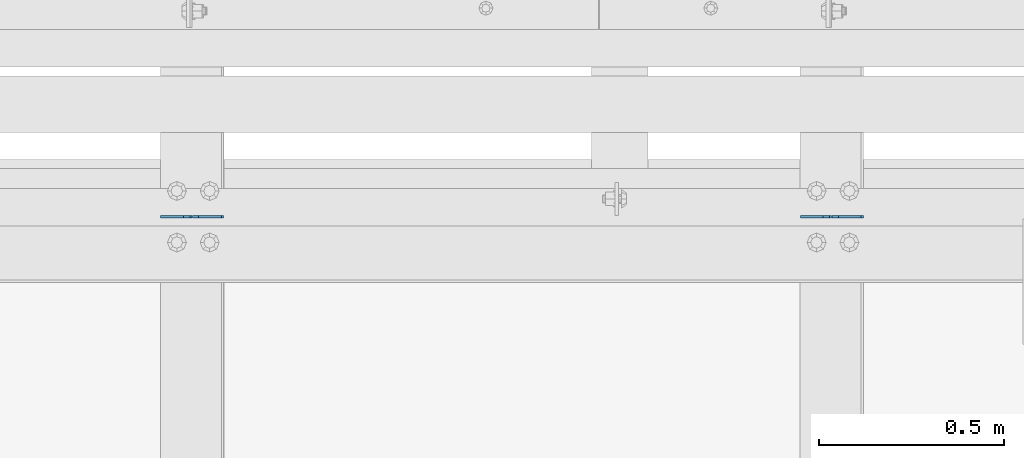
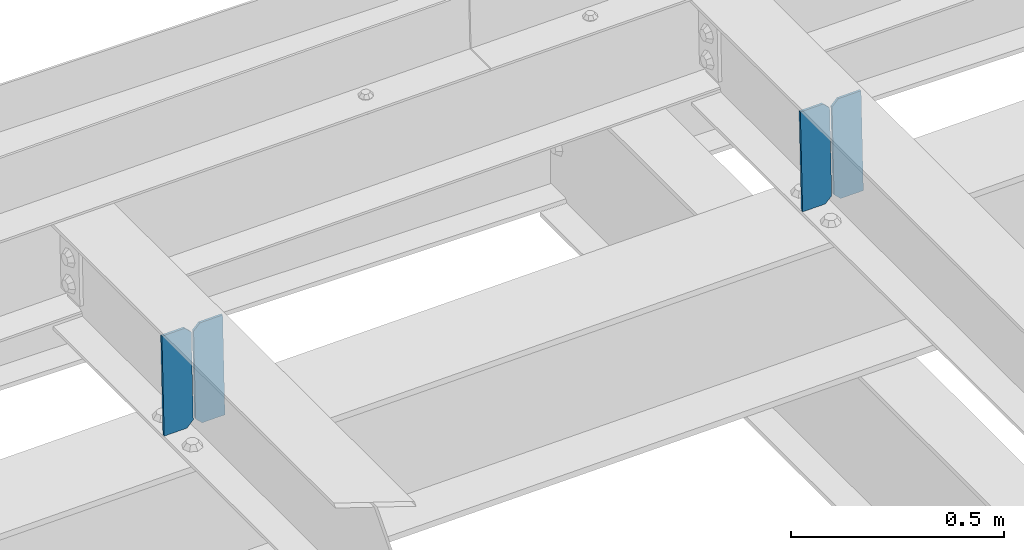
# One storey, part 3457 of 3843: 4 plates, 2 elements without a shape of their own.
"""IFC2X3 building model written with IfcOpenShell, lengths in millimetres."""

from ifc_helpers import new_model, si_unit, frame, origin_with_axes, place, context, subcontext, project, spatial, faceted_brep, material, type_object, element, aggregate, save


model = new_model("IFC2X3")

# Units and contexts
model_context = context("Model", 3, precision=1e-05, world=origin_with_axes())
body_context = subcontext(model_context, "Body", "Model", "MODEL_VIEW")
ifc_project = project(units=[si_unit("LENGTHUNIT", "METRE", prefix="MILLI"), si_unit("AREAUNIT", "SQUARE_METRE"), si_unit("VOLUMEUNIT", "CUBIC_METRE"), si_unit("MASSUNIT", "GRAM", prefix="KILO"), si_unit("TIMEUNIT", "SECOND"), si_unit("PLANEANGLEUNIT", "RADIAN"), si_unit("SOLIDANGLEUNIT", "STERADIAN"), si_unit("THERMODYNAMICTEMPERATUREUNIT", "DEGREE_CELSIUS"), si_unit("LUMINOUSINTENSITYUNIT", "LUMEN")], contexts=[model_context])

# Site, building, storey
site_placement = place(None, origin_with_axes())
site = spatial("IfcSite", under=ifc_project, at=site_placement, CompositionType="ELEMENT")
building_placement = place(site_placement, origin_with_axes())
building = spatial("IfcBuilding", under=site, at=building_placement, Name="Undefined", CompositionType="ELEMENT")
storey_placement = place(building_placement, origin_with_axes())
storey = spatial("IfcBuildingStorey", under=building, at=storey_placement, Name="Undefined", CompositionType="ELEMENT", Elevation=0.0)

# Assembly, plates
assembly_1_placement = place(storey_placement, origin_with_axes())
assembly_1 = element("IfcElementAssembly", 1, at=assembly_1_placement, inside=storey, Name="BEAM", AssemblyPlace="NOTDEFINED", PredefinedType="RIGID_FRAME")
ifc_material = material(Name="STEEL/A572-50")
plate_type = type_object("IfcPlateType", PredefinedType="NOTDEFINED")
plate_1_placement = place(assembly_1_placement, frame((47345.3464783859, 92214.4343372321, 45657.6910033379), z_axis=(-0.0211520976064639, 0.000583214000143924, 0.999776099248365), x_axis=(-0.999776269355723, -1.23390000258365e-05, -0.0211520940075068)))
plate_1 = element("IfcPlate", 2, at=plate_1_placement, type_object=plate_type, material=ifc_material, Name="STIFFENER", context=body_context, shape_type="Brep", body=[
    faceted_brep([(0.0, -3.17499999999927, 0.0), (6.83940015733242e-10, -3.17499999996653, 288.924999998613), (6.54836185276508e-10, 3.17500000001746, 288.924999998591), (0.0, 3.17499999999927, 0.0), (61.9125003828667, -3.17499999997744, 288.924999998599), (61.9125003828522, 3.17500000002838, 288.924999998584), (79.3750000013097, -3.17499999997744, 271.462500380039), (79.375000001266, 3.17500000002838, 271.462500380017), (79.375000000713, -3.17499999999927, 17.4624996185448), (79.3750000006694, 3.17500000000291, 17.462499618523), (61.9125003821828, -3.17499999999563, -1.45519152283669e-11), (61.9125003821682, 3.17500000000655, -2.91038304567337e-11)], [[[0, 1, 2, 3]], [[1, 4, 5, 2]], [[4, 6, 7, 5]], [[6, 8, 9, 7]], [[8, 10, 11, 9]], [[10, 0, 3, 11]], [[5, 7, 9, 11, 3, 2]], [[10, 8, 6, 4, 1, 0]]]),
])
plate_2_placement = place(assembly_1_placement, frame((47259.6406576962, 92214.4332794759, 45655.8777400451), z_axis=(-0.0211520976064639, 0.000583214000143924, 0.999776099248365), x_axis=(-0.999776269355723, -1.23390000258365e-05, -0.0211520940075068)))
plate_2 = element("IfcPlate", 3, at=plate_2_placement, type_object=plate_type, material=ifc_material, Name="STIFFENER", context=body_context, shape_type="Brep", body=[
    faceted_brep([(5.82076609134674e-11, -3.17499999999927, 17.4624996185667), (6.25732354819775e-10, -3.17499999997744, 271.462500380054), (5.82076609134674e-10, 3.17500000002474, 271.462500380039), (0.0, 3.17500000000655, 17.4624996185521), (17.462499619156, -3.17499999997744, 288.924999998606), (17.4624996191269, 3.17500000002474, 288.924999998591), (79.3750000013242, -3.17500000025029, 288.924999998591), (79.3750000013097, 3.1749999997337, 288.92499999857), (79.3750000006548, -3.17500000026484, -2.18278728425503e-11), (79.3750000006403, 3.17499999969732, -2.91038304567337e-11), (17.4624996184866, -3.17500000000291, 7.27595761418343e-12), (17.462499618443, 3.17500000000291, -7.27595761418343e-12)], [[[0, 1, 2, 3]], [[1, 4, 5, 2]], [[4, 6, 7, 5]], [[6, 8, 9, 7]], [[8, 10, 11, 9]], [[10, 0, 3, 11]], [[5, 7, 9, 11, 3, 2]], [[10, 8, 6, 4, 1, 0]]]),
])
aggregate(assembly_1, [plate_1, plate_2])

assembly_2_placement = place(storey_placement, origin_with_axes())
assembly_2 = element("IfcElementAssembly", 4, at=assembly_2_placement, inside=storey, Name="BEAM", AssemblyPlace="NOTDEFINED", PredefinedType="RIGID_FRAME")
plate_3_placement = place(assembly_2_placement, frame((45611.7964783468, 92214.477449511, 45620.9568449149), z_axis=(-0.0211520975333623, 0.000488609999985782, 0.999776149960684), x_axis=(-0.999776269357269, -1.03370000525781e-05, -0.0211520950075214)))
plate_3 = element("IfcPlate", 5, at=plate_3_placement, type_object=plate_type, material=ifc_material, Name="STIFFENER", context=body_context, shape_type="Brep", body=[
    faceted_brep([(0.0, -3.17499999999927, 0.0), (6.83940015733242e-10, -3.17499999996653, 288.924999998613), (6.54836185276508e-10, 3.17500000001746, 288.924999998591), (0.0, 3.17499999999927, 0.0), (61.9125003828667, -3.17499999997744, 288.924999998599), (61.9125003828522, 3.17500000002838, 288.924999998584), (79.3750000013097, -3.17499999997744, 271.462500380039), (79.375000001266, 3.17500000002838, 271.462500380017), (79.375000000713, -3.17499999999927, 17.4624996185448), (79.3750000006694, 3.17500000000291, 17.462499618523), (61.9125003821828, -3.17499999999563, -1.45519152283669e-11), (61.9125003821682, 3.17500000000655, -2.91038304567337e-11)], [[[0, 1, 2, 3]], [[1, 4, 5, 2]], [[4, 6, 7, 5]], [[6, 8, 9, 7]], [[8, 10, 11, 9]], [[10, 0, 3, 11]], [[5, 7, 9, 11, 3, 2]], [[10, 8, 6, 4, 1, 0]]]),
])
plate_4_placement = place(assembly_2_placement, frame((45526.0906576572, 92214.4765633333, 45619.1435815301), z_axis=(-0.0211520975333623, 0.000488609999985782, 0.999776149960684), x_axis=(-0.999776269357269, -1.03370000525781e-05, -0.0211520950075214)))
plate_4 = element("IfcPlate", 6, at=plate_4_placement, type_object=plate_type, material=ifc_material, Name="STIFFENER", context=body_context, shape_type="Brep", body=[
    faceted_brep([(5.82076609134674e-11, -3.17499999999927, 17.4624996185667), (6.25732354819775e-10, -3.17499999997744, 271.462500380054), (5.82076609134674e-10, 3.17500000002474, 271.462500380039), (0.0, 3.17500000000655, 17.4624996185521), (17.462499619156, -3.17499999997744, 288.924999998606), (17.4624996191269, 3.17500000002474, 288.924999998591), (79.3750000013242, -3.17500000025029, 288.924999998591), (79.3750000013097, 3.1749999997337, 288.92499999857), (79.3750000006548, -3.17500000026484, -2.18278728425503e-11), (79.3750000006403, 3.17499999969732, -2.91038304567337e-11), (17.4624996184866, -3.17500000000291, 7.27595761418343e-12), (17.462499618443, 3.17500000000291, -7.27595761418343e-12)], [[[0, 1, 2, 3]], [[1, 4, 5, 2]], [[4, 6, 7, 5]], [[6, 8, 9, 7]], [[8, 10, 11, 9]], [[10, 0, 3, 11]], [[5, 7, 9, 11, 3, 2]], [[10, 8, 6, 4, 1, 0]]]),
])
aggregate(assembly_2, [plate_3, plate_4])

save(model, "model.ifc")
